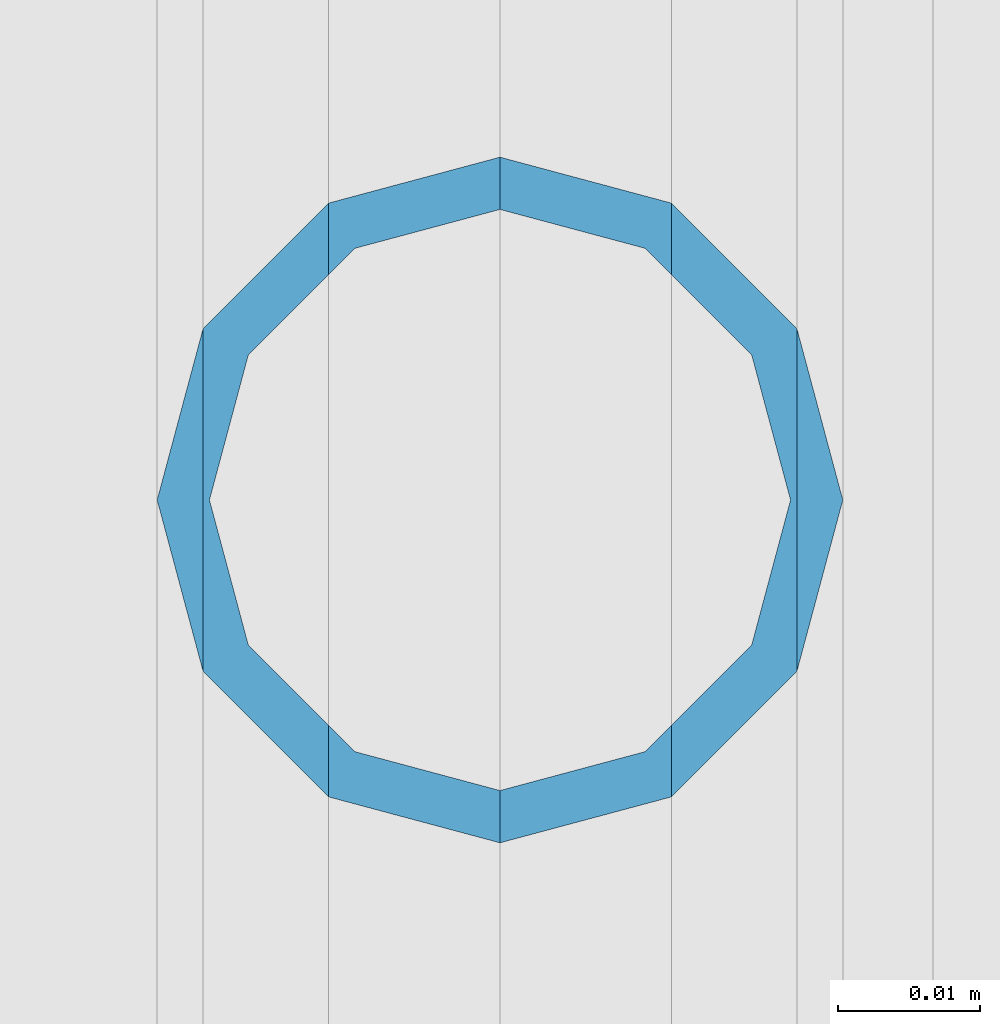
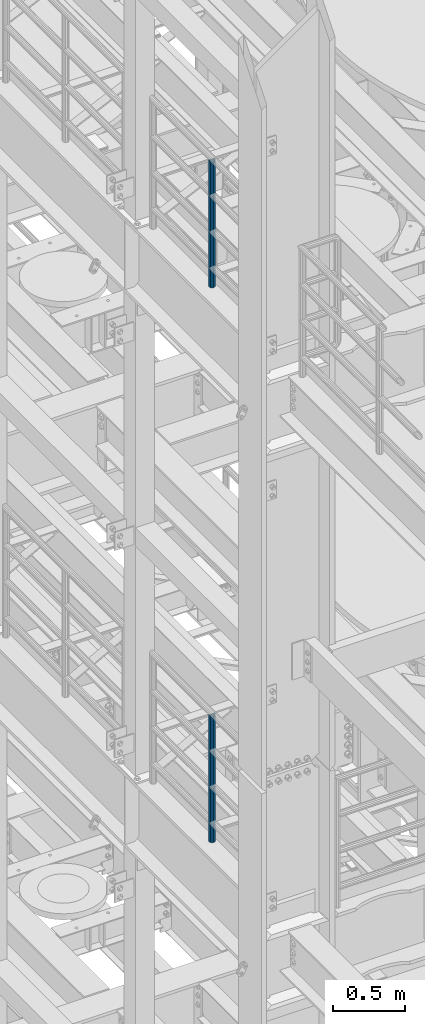
# One storey, part 618 of 1876: 2 columns, 2 elements without a shape of their own.
"""IFC2X3 building model written with IfcOpenShell, lengths in millimetres."""

from ifc_helpers import new_model, si_unit, frame, origin_with_axes, place, context, subcontext, project, spatial, faceted_brep, material, type_object, element, aggregate, save


model = new_model("IFC2X3")

# Units and contexts
model_context = context("Model", 3, precision=1e-05, world=origin_with_axes())
body_context = subcontext(model_context, "Body", "Model", "MODEL_VIEW")
ifc_project = project(units=[si_unit("LENGTHUNIT", "METRE", prefix="MILLI"), si_unit("AREAUNIT", "SQUARE_METRE"), si_unit("VOLUMEUNIT", "CUBIC_METRE"), si_unit("MASSUNIT", "GRAM", prefix="KILO"), si_unit("TIMEUNIT", "SECOND"), si_unit("PLANEANGLEUNIT", "RADIAN"), si_unit("SOLIDANGLEUNIT", "STERADIAN"), si_unit("THERMODYNAMICTEMPERATUREUNIT", "DEGREE_CELSIUS"), si_unit("LUMINOUSINTENSITYUNIT", "LUMEN")], contexts=[model_context])

# Site, building, storey
site_placement = place(None, origin_with_axes())
site = spatial("IfcSite", under=ifc_project, at=site_placement, CompositionType="ELEMENT")
building_placement = place(site_placement, origin_with_axes())
building = spatial("IfcBuilding", under=site, at=building_placement, Name="Undefined", CompositionType="ELEMENT")
storey_placement = place(building_placement, origin_with_axes())
storey = spatial("IfcBuildingStorey", under=building, at=storey_placement, Name="Undefined", CompositionType="ELEMENT", Elevation=0.0)

# Assembly, column
assembly_1_placement = place(storey_placement, origin_with_axes())
assembly_1 = element("IfcElementAssembly", 1, at=assembly_1_placement, inside=storey, Name="RAIL", AssemblyPlace="NOTDEFINED", PredefinedType="RIGID_FRAME")
ifc_material = material()
column_type = type_object("IfcColumnType", Name="PIPE1-1/2SCH40", PredefinedType="NOTDEFINED")
column_1_placement = place(assembly_1_placement, frame((-1.81898940354586e-12, -3542.7031, 17983.2), z_axis=(0.0, 1.0, 0.0), x_axis=(0.0, 0.0, 1.0)))
column_1 = element("IfcColumn", 2, at=column_1_placement, type_object=column_type, material=ifc_material, Name="POST", ObjectType="PIPE1-1/2SCH40", context=body_context, shape_type="Brep", body=[
    faceted_brep([(1055.42780700668, -12.0650000000001, 20.8971929933186), (1055.42780700668, -12.0650000000001, 15.8661214311805), (1054.93437856882, -10.2235000000001, 17.7076214311801), (1052.195, 0.0, 20.4470000000001), (1052.195, 0.0, 24.1300000000001), (1054.93437856882, 10.2235000000001, 17.7076214311801), (1055.42780700668, 12.0650000000001, 15.8661214311805), (1055.42780700668, 12.0650000000001, 20.8971929933186), (1076.325, 24.1300000000001, 0.0), (1064.26, 20.8971929933184, 12.0649999999996), (1064.25999999999, 20.8971929933186, -12.0649999999996), (1061.07042843786, 17.7076214311803, 10.2235000000001), (1063.80980700668, 20.4469999999999, 0.0), (1061.07042843786, 17.7076214311803, -10.2235000000001), (1055.42780700668, 12.0650000000001, -15.8661214311805), (1055.42780700667, 12.0649999999996, -20.8971929933186), (1054.93437856882, 10.2235000000001, -17.7076214311801), (1052.195, 0.0, -20.4470000000001), (1052.19499999999, 0.0, -24.1300000000001), (1055.42780700668, -12.0650000000001, -15.8661214311805), (1055.42780700667, -12.0649999999996, -20.8971929933186), (1054.93437856882, -10.2235000000001, -17.7076214311801), (1076.325, -24.1300000000001, 0.0), (1064.25999999999, -20.8971929933186, -12.0649999999996), (1064.26, -20.8971929933184, 12.0649999999996), (1061.07042843786, -17.7076214311803, -10.2235000000001), (1063.80980700668, -20.4469999999999, 0.0), (1061.07042843786, -17.7076214311803, 10.2235000000001), (0.0, -20.8971929933184, -12.0649999999996), (0.0, -12.0650000000001, -20.8971929933186), (-1.45519152283669e-11, 0.0, -24.130000000001), (0.0, 12.0650000000001, -20.8971929933186), (0.0, 20.8971929933184, -12.0649999999996), (0.0, 24.1299999999992, 0.0), (0.0, 20.8971929933184, 12.0649999999996), (0.0, 12.0650000000001, 20.8971929933186), (-1.45519152283669e-11, 0.0, 24.130000000001), (0.0, -12.0650000000001, 20.8971929933186), (0.0, -20.8971929933184, 12.0649999999996), (0.0, -24.1299999999992, 0.0), (0.0, -17.7076214311803, -10.2235000000001), (0.0, -10.2235000000001, -17.7076214311801), (-1.45519152283669e-11, 0.0, -20.4470000000001), (0.0, 10.2235000000001, -17.7076214311801), (0.0, 17.7076214311803, -10.2235000000001), (0.0, 20.4469999999999, 0.0), (0.0, 17.7076214311803, 10.2235000000001), (0.0, 10.2235000000001, 17.7076214311801), (-1.45519152283669e-11, 0.0, 20.4470000000001), (0.0, -10.2235000000001, 17.7076214311801), (0.0, -17.7076214311803, 10.2235000000001), (0.0, -20.4469999999999, 0.0)], [[[0, 1, 2, 3, 4]], [[4, 3, 5, 6, 7]], [[8, 9, 10]], [[7, 6, 11, 12, 13, 14, 15, 10, 9]], [[16, 17, 18, 15, 14]], [[19, 20, 18, 17, 21]], [[22, 23, 24]], [[24, 23, 20, 19, 25, 26, 27, 1, 0]], [[28, 29, 20, 23]], [[29, 30, 18, 20]], [[30, 31, 15, 18]], [[31, 32, 10, 15]], [[32, 33, 8, 10]], [[33, 34, 9, 8]], [[34, 35, 7, 9]], [[35, 36, 4, 7]], [[36, 37, 0, 4]], [[37, 38, 24, 0]], [[38, 39, 22, 24]], [[39, 28, 23, 22]], [[38, 37, 36, 35, 34, 33, 32, 31, 30, 29, 28, 39], [40, 41, 42, 43, 44, 45, 46, 47, 48, 49, 50, 51]], [[40, 51, 26, 25]], [[21, 41, 40, 25, 19]], [[42, 41, 21, 17]], [[43, 42, 17, 16]], [[44, 43, 16, 14, 13]], [[45, 44, 13, 12]], [[46, 45, 12, 11]], [[5, 47, 46, 11, 6]], [[48, 47, 5, 3]], [[49, 48, 3, 2]], [[50, 49, 2, 1, 27]], [[51, 50, 27, 26]]]),
])
aggregate(assembly_1, [column_1])

assembly_2_placement = place(storey_placement, origin_with_axes())
assembly_2 = element("IfcElementAssembly", 3, at=assembly_2_placement, inside=storey, Name="RAIL", AssemblyPlace="NOTDEFINED", PredefinedType="RIGID_FRAME")
column_2_placement = place(assembly_2_placement, frame((-1.81898940354586e-12, -3542.7031, 13309.6), z_axis=(0.0, 1.0, 0.0), x_axis=(0.0, 0.0, 1.0)))
column_2 = element("IfcColumn", 4, at=column_2_placement, type_object=column_type, material=ifc_material, Name="POST", ObjectType="PIPE1-1/2SCH40", context=body_context, shape_type="Brep", body=[
    faceted_brep([(1055.42780700668, -12.0650000000001, 20.8971929933186), (1055.42780700668, -12.0650000000001, 15.8661214311805), (1054.93437856882, -10.2235000000001, 17.7076214311801), (1052.195, 0.0, 20.4470000000001), (1052.195, 0.0, 24.1300000000001), (1054.93437856882, 10.2235000000001, 17.7076214311801), (1055.42780700668, 12.0650000000001, 15.8661214311805), (1055.42780700668, 12.0650000000001, 20.8971929933186), (1076.325, 24.1300000000001, 0.0), (1064.26, 20.8971929933184, 12.0649999999996), (1064.25999999999, 20.8971929933186, -12.0649999999996), (1061.07042843786, 17.7076214311803, 10.2235000000001), (1063.80980700668, 20.4469999999999, 0.0), (1061.07042843786, 17.7076214311803, -10.2235000000001), (1055.42780700668, 12.0650000000001, -15.8661214311805), (1055.42780700667, 12.0649999999996, -20.8971929933186), (1054.93437856882, 10.2235000000001, -17.7076214311801), (1052.195, 0.0, -20.4470000000001), (1052.19499999999, 0.0, -24.1300000000001), (1055.42780700668, -12.0650000000001, -15.8661214311805), (1055.42780700667, -12.0649999999996, -20.8971929933186), (1054.93437856882, -10.2235000000001, -17.7076214311801), (1076.325, -24.1300000000001, 0.0), (1064.25999999999, -20.8971929933186, -12.0649999999996), (1064.26, -20.8971929933184, 12.0649999999996), (1061.07042843786, -17.7076214311803, -10.2235000000001), (1063.80980700668, -20.4469999999999, 0.0), (1061.07042843786, -17.7076214311803, 10.2235000000001), (0.0, -20.8971929933184, -12.0649999999996), (0.0, -12.0650000000001, -20.8971929933186), (-1.45519152283669e-11, 0.0, -24.130000000001), (0.0, 12.0650000000001, -20.8971929933186), (0.0, 20.8971929933184, -12.0649999999996), (0.0, 24.1299999999992, 0.0), (0.0, 20.8971929933184, 12.0649999999996), (0.0, 12.0650000000001, 20.8971929933186), (-1.45519152283669e-11, 0.0, 24.130000000001), (0.0, -12.0650000000001, 20.8971929933186), (0.0, -20.8971929933184, 12.0649999999996), (0.0, -24.1299999999992, 0.0), (0.0, -17.7076214311803, -10.2235000000001), (0.0, -10.2235000000001, -17.7076214311801), (-1.45519152283669e-11, 0.0, -20.4470000000001), (0.0, 10.2235000000001, -17.7076214311801), (0.0, 17.7076214311803, -10.2235000000001), (0.0, 20.4469999999999, 0.0), (0.0, 17.7076214311803, 10.2235000000001), (0.0, 10.2235000000001, 17.7076214311801), (-1.45519152283669e-11, 0.0, 20.4470000000001), (0.0, -10.2235000000001, 17.7076214311801), (0.0, -17.7076214311803, 10.2235000000001), (0.0, -20.4469999999999, 0.0)], [[[0, 1, 2, 3, 4]], [[4, 3, 5, 6, 7]], [[8, 9, 10]], [[7, 6, 11, 12, 13, 14, 15, 10, 9]], [[16, 17, 18, 15, 14]], [[19, 20, 18, 17, 21]], [[22, 23, 24]], [[24, 23, 20, 19, 25, 26, 27, 1, 0]], [[28, 29, 20, 23]], [[29, 30, 18, 20]], [[30, 31, 15, 18]], [[31, 32, 10, 15]], [[32, 33, 8, 10]], [[33, 34, 9, 8]], [[34, 35, 7, 9]], [[35, 36, 4, 7]], [[36, 37, 0, 4]], [[37, 38, 24, 0]], [[38, 39, 22, 24]], [[39, 28, 23, 22]], [[38, 37, 36, 35, 34, 33, 32, 31, 30, 29, 28, 39], [40, 41, 42, 43, 44, 45, 46, 47, 48, 49, 50, 51]], [[40, 51, 26, 25]], [[21, 41, 40, 25, 19]], [[42, 41, 21, 17]], [[43, 42, 17, 16]], [[44, 43, 16, 14, 13]], [[45, 44, 13, 12]], [[46, 45, 12, 11]], [[5, 47, 46, 11, 6]], [[48, 47, 5, 3]], [[49, 48, 3, 2]], [[50, 49, 2, 1, 27]], [[51, 50, 27, 26]]]),
])
aggregate(assembly_2, [column_2])

save(model, "model.ifc")
